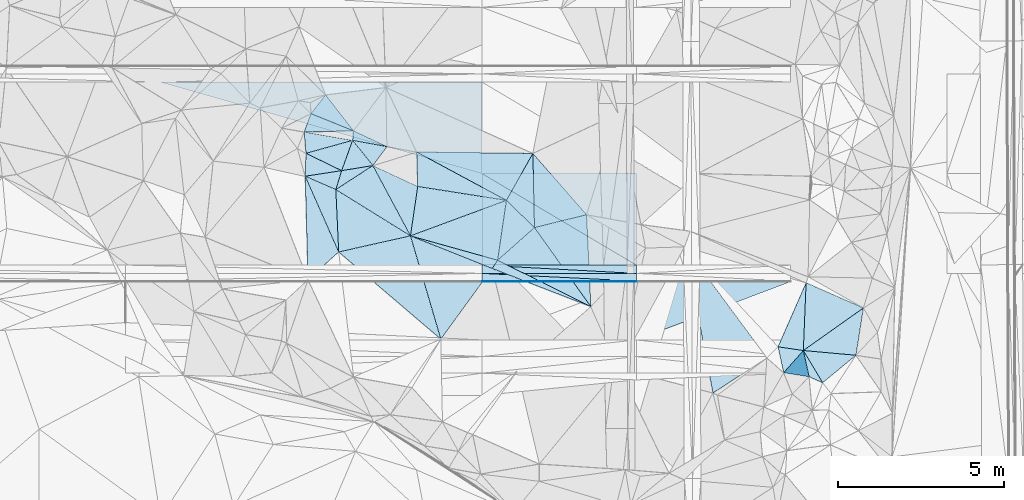
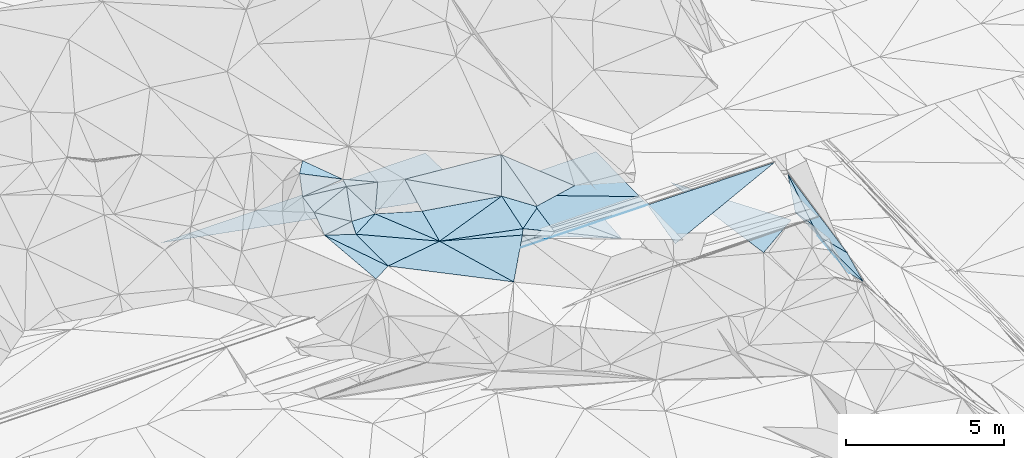
# One storey, part 60 of 275: 46 plates.
"""IFC2X3 building model written with IfcOpenShell, lengths in millimetres."""

import ifcopenshell
import ifcopenshell.guid

model = None  # the IFC model being written
_history = None  # IfcOwnerHistory: only IFC2X3 demands one
_inside = {}  # id of a spatial element -> (the spatial element, [elements in it])
_under = {}  # id of a project, library or spatial element -> (it, [spatial elements below it])
_declared = {}  # id of a project -> (the project, [libraries it declares])
_typed = {}  # id of a type object -> (the type object, [elements of that type])
_made_of = {}  # id of a material, layer set ... -> (it, [elements and type objects made of it])


def new_model(schema):
    """Start an empty IFC model of exactly this schema.

    Asked for "IFC4X3", IfcOpenShell would pick the latest addendum, in which some entities
    have other attributes; the version numbers below select the first issue.
    IFC2X3 requires an IfcOwnerHistory on every rooted entity: one is made here for all.
    """
    global model, _history
    if schema == "IFC4X3":
        model = ifcopenshell.file(schema_version=(4, 3, 0, 0))
    else:
        model = ifcopenshell.file(schema=schema)
    _inside.clear()
    _under.clear()
    _declared.clear()
    _typed.clear()
    _made_of.clear()
    _history = None
    if model.schema == "IFC2X3":
        org = make("IfcOrganization", Name="unknown")
        user = make(
            "IfcPersonAndOrganization",
            ThePerson=make("IfcPerson", FamilyName="unknown"),
            TheOrganization=org,
        )
        app = make(
            "IfcApplication",
            ApplicationDeveloper=org,
            Version="unknown",
            ApplicationFullName="unknown",
            ApplicationIdentifier="unknown",
        )
        _history = make(
            "IfcOwnerHistory",
            OwningUser=user,
            OwningApplication=app,
            ChangeAction="ADDED",
            CreationDate=0,
        )
    return model


def make(cls, **values):
    """One entity of the class cls with the attributes given. An attribute that is None is left unset."""
    return model.create_entity(
        cls, **{name: value for name, value in values.items() if value is not None}
    )


def rooted(cls, **values):
    """An entity with a GlobalId (a new one), such as an element, a storey or a relation."""
    return make(cls, GlobalId=ifcopenshell.guid.new(), OwnerHistory=_history, **values)


def si_unit(unit_type, name, prefix=None):
    """IfcSIUnit, for example si_unit("LENGTHUNIT", "METRE", prefix="MILLI")."""
    return make("IfcSIUnit", UnitType=unit_type, Prefix=prefix, Name=name)


def assignment(units):
    """IfcUnitAssignment: the units of a project."""
    return None if units is None else make("IfcUnitAssignment", Units=units)


def point(xyz):
    """IfcCartesianPoint."""
    return None if xyz is None else make("IfcCartesianPoint", Coordinates=xyz)


def direction(xyz):
    """IfcDirection."""
    return None if xyz is None else make("IfcDirection", DirectionRatios=xyz)


def frame(location, z_axis=None, x_axis=None):
    """IfcAxis2Placement3D, a coordinate frame: its origin and axes. An axis left out is left unset."""
    return make(
        "IfcAxis2Placement3D",
        Location=point(location),
        Axis=direction(z_axis),
        RefDirection=direction(x_axis),
    )


def origin_with_axes():
    """The frame at (0, 0, 0) with the z axis (0, 0, 1) and the x axis (1, 0, 0) written out."""
    return frame((0.0, 0.0, 0.0), z_axis=(0.0, 0.0, 1.0), x_axis=(1.0, 0.0, 0.0))


def place(relative_to, where):
    """IfcLocalPlacement: puts the frame where relative to a parent placement (None: the world)."""
    return make(
        "IfcLocalPlacement", PlacementRelTo=relative_to, RelativePlacement=where
    )


def context(
    kind, dimensions, precision=None, world=None, true_north=None, identifier=None
):
    """IfcGeometricRepresentationContext, for example the 3D "Model" context."""
    return make(
        "IfcGeometricRepresentationContext",
        ContextIdentifier=identifier,
        ContextType=kind,
        CoordinateSpaceDimension=dimensions,
        Precision=precision,
        WorldCoordinateSystem=world,
        TrueNorth=true_north,
    )


def subcontext(parent, identifier, kind, view, scale=None):
    """IfcGeometricRepresentationSubContext, for example "Body" below "Model"."""
    return make(
        "IfcGeometricRepresentationSubContext",
        ContextIdentifier=identifier,
        ContextType=kind,
        ParentContext=parent,
        TargetScale=scale,
        TargetView=view,
    )


def project(units=None, contexts=None):
    """IfcProject with its units and contexts."""
    return rooted(
        "IfcProject",
        Name="project",
        RepresentationContexts=contexts,
        UnitsInContext=assignment(units),
    )


def spatial(cls, under=None, at=None, **own):
    """A site, building, storey or space (cls), placed at a placement, below another one or the project."""
    s = rooted(cls, ObjectPlacement=at, **own)
    if under is not None:
        _under.setdefault(under.id(), (under, []))[1].append(s)
    return s


def polyline(points):
    """IfcPolyline through the points."""
    return make("IfcPolyline", Points=[point(p) for p in points])


def outline(outer, holes=None, kind="AREA"):
    """IfcArbitraryClosedProfileDef: a profile drawn as a closed curve; with holes, ...WithVoids."""
    if holes is None:
        return make("IfcArbitraryClosedProfileDef", ProfileType=kind, OuterCurve=outer)
    return make(
        "IfcArbitraryProfileDefWithVoids",
        ProfileType=kind,
        OuterCurve=outer,
        InnerCurves=holes,
    )


def extrude(swept, where, along, depth):
    """IfcExtrudedAreaSolid: the profile swept, set in the frame where, extruded along a direction by depth."""
    return make(
        "IfcExtrudedAreaSolid",
        SweptArea=swept,
        Position=where,
        ExtrudedDirection=direction(along),
        Depth=depth,
    )


def shape(context_of_items, identifier, shape_type, items):
    """IfcShapeRepresentation: the items that make up one representation, for example the "Body"."""
    return make(
        "IfcShapeRepresentation",
        ContextOfItems=context_of_items,
        RepresentationIdentifier=identifier,
        RepresentationType=shape_type,
        Items=items,
    )


def material(Name=None, Category=None):
    """IfcMaterial."""
    return make("IfcMaterial", Name=Name, Category=Category)


def made_of(thing, what):
    """Note that an element or type object is made of a material, layer set ...; save() writes the relation."""
    if what is not None:
        _made_of.setdefault(what.id(), (what, []))[1].append(thing)
    return thing


def type_object(cls, material=None, **own):
    """A type object (cls), such as IfcWallType, which elements share."""
    return made_of(rooted(cls, **own), material)


def element(
    cls,
    number,
    at=None,
    inside=None,
    cuts=None,
    type_object=None,
    material=None,
    context=None,
    identifier="Body",
    shape_type=None,
    held_by="IfcProductDefinitionShape",
    body=None,
    shapes=None,
    **own,
):
    """One element of the class cls, such as IfcWall. Its Tag is "e" and its number.

    at: its placement. inside: the storey or other place that contains it. cuts: it is an
    opening in that element (IfcRelVoidsElement). A single representation is given by context,
    identifier, shape_type and body (its items); several are given by shapes. held_by: the class
    of the entity that holds the representations. save() writes the other relations.
    """
    e = rooted(cls, Tag="e%d" % number, ObjectPlacement=at, **own)
    if body is not None:
        shapes = [shape(context, identifier, shape_type, body)]
    if shapes is not None:
        e.Representation = make(held_by, Representations=shapes)
    if inside is not None:
        _inside.setdefault(inside.id(), (inside, []))[1].append(e)
    if cuts is not None:
        rooted(
            "IfcRelVoidsElement", RelatingBuildingElement=cuts, RelatedOpeningElement=e
        )
    if type_object is not None:
        _typed.setdefault(type_object.id(), (type_object, []))[1].append(e)
    return made_of(e, material)


def aggregate(whole, parts):
    """IfcRelAggregates: a whole, such as a stair, and the parts it consists of."""
    return rooted("IfcRelAggregates", RelatingObject=whole, RelatedObjects=parts)


def save(model, path):
    """Write the relations noted so far, then the file.

    IfcRelAggregates (storeys below a building ...), IfcRelContainedInSpatialStructure (elements
    in a storey), IfcRelDefinesByType, IfcRelAssociatesMaterial and IfcRelDeclares: one each for
    every whole, place, type object, material and project.
    """
    for whole, parts in _under.values():
        aggregate(whole, parts)
    for where, things in _inside.values():
        rooted(
            "IfcRelContainedInSpatialStructure",
            RelatedElements=things,
            RelatingStructure=where,
        )
    for kind, things in _typed.values():
        rooted("IfcRelDefinesByType", RelatedObjects=things, RelatingType=kind)
    for what, things in _made_of.values():
        rooted("IfcRelAssociatesMaterial", RelatedObjects=things, RelatingMaterial=what)
    for by, libraries in _declared.values():
        rooted("IfcRelDeclares", RelatingContext=by, RelatedDefinitions=libraries)
    model.write(path)


model = new_model("IFC2X3")

# Units and contexts
model_context = context("Model", 3, precision=1e-05, world=origin_with_axes())
body_context = subcontext(model_context, "Body", "Model", "MODEL_VIEW")
ifc_project = project(units=[si_unit("LENGTHUNIT", "METRE", prefix="MILLI"), si_unit("AREAUNIT", "SQUARE_METRE"), si_unit("VOLUMEUNIT", "CUBIC_METRE"), si_unit("MASSUNIT", "GRAM", prefix="KILO"), si_unit("TIMEUNIT", "SECOND"), si_unit("PLANEANGLEUNIT", "RADIAN"), si_unit("SOLIDANGLEUNIT", "STERADIAN"), si_unit("THERMODYNAMICTEMPERATUREUNIT", "DEGREE_CELSIUS"), si_unit("LUMINOUSINTENSITYUNIT", "LUMEN")], contexts=[model_context])

# Site, building, storey
site_placement = place(None, origin_with_axes())
site = spatial("IfcSite", under=ifc_project, at=site_placement, CompositionType="ELEMENT")
building_placement = place(site_placement, origin_with_axes())
building = spatial("IfcBuilding", under=site, at=building_placement, Name="Undefined", CompositionType="ELEMENT")
storey_placement = place(building_placement, origin_with_axes())
storey = spatial("IfcBuildingStorey", under=building, at=storey_placement, Name="Undefined", CompositionType="ELEMENT", Elevation=0.0)

# Plates
ifc_material = material()
plate_type_1 = type_object("IfcPlateType", PredefinedType="NOTDEFINED")
for number, where, z_axis, x_axis, name in (
    (1, (-105469.357591883, 60542.9469194419, 49093.5671622672), (0.0070360534464846, 0.0249911698384873, -0.999662910876462), (-0.999975239635043, 5.72709690146696e-05, -0.00703682008264182), "00_PR"),
    (2, (-110107.970218176, 63293.2126112897, 49129.6741619064), (0.0070360534464846, 0.0249911698384873, -0.999662910876462), (0.99997523963564, -5.72709999785377e-05, 0.00703681999743575), "00_PR"),
):
    element("IfcPlate", number, at=place(storey_placement, frame(where, z_axis=z_axis, x_axis=x_axis)), inside=storey, type_object=plate_type_1, material=ifc_material, Name=name, context=body_context, shape_type="SweptSolid", body=[
        extrude(outline(polyline([(0.0, 0.0), (4638.88525390625, 2.71393219009042e-09), (4638.4013671875, 2750.85913085938), (0.0, 0.0)])), frame((-8.85201319254618e-08, 2.18876761149539e-07, -0.5000001331573), z_axis=(0.0, 0.0, 1.0), x_axis=(1.0, 0.0, 0.0)), (0.0, 0.0, 1.0), 1.0),
    ])
plate_1_placement = place(storey_placement, frame((-119776.166734468, 66043.7427297711, 48980.4271662069), z_axis=(0.00832149793297365, -0.0249918019511436, -0.9996530210565), x_axis=(0.999965340787191, -5.73519775278889e-05, 0.0083254990906575)))
element("IfcPlate", 3, at=plate_1_placement, inside=storey, type_object=plate_type_1, material=ifc_material, Name="00_PR", context=body_context, shape_type="SweptSolid", body=[
    extrude(outline(polyline([(0.0, 0.0), (9668.689453125, -4.80504240840673e-08), (9669.2626953125, 2750.85913085938), (0.0, 0.0)])), frame((-8.85201319254618e-08, 2.18876761149539e-07, -0.5000001331573), z_axis=(0.0, 0.0, 1.0), x_axis=(1.0, 0.0, 0.0)), (0.0, 0.0, 1.0), 1.0),
])
plate_type_2 = type_object("IfcPlateType", PredefinedType="NOTDEFINED")
plate_2_placement = place(storey_placement, frame((-105469.371915904, 60292.9469172956, 49087.3171623926), z_axis=(0.0070360534464846, 0.0249911698384873, -0.999662910876462), x_axis=(-0.998531697023623, 0.0538718169725224, -0.00568131808672126)))
element("IfcPlate", 4, at=plate_2_placement, inside=storey, type_object=plate_type_2, material=ifc_material, Name="00_PR", context=body_context, shape_type="SweptSolid", body=[
    extrude(outline(polyline([(0.0, 0.0), (4645.5771484375, 2.16532498598099e-08), (13.4181432723999, 249.717880249023), (0.0, 0.0)])), frame((-8.85201319254618e-08, 2.18876761149539e-07, -0.5000001331573), z_axis=(0.0, 0.0, 1.0), x_axis=(1.0, 0.0, 0.0)), (0.0, 0.0, 1.0), 1.0),
])
plate_3_placement = place(storey_placement, frame((-105469.371915904, 60292.9469172956, 49087.3171623926), z_axis=(0.0070360534464846, 0.0249911698384873, -0.999662910876462), x_axis=(-0.999975239635043, 5.72709690146696e-05, -0.00703682008264182)))
element("IfcPlate", 5, at=plate_3_placement, inside=storey, type_object=plate_type_2, material=ifc_material, Name="00_PR", context=body_context, shape_type="SweptSolid", body=[
    extrude(outline(polyline([(0.0, 0.0), (4638.88525390625, 2.71393219009042e-09), (4638.8408203125, 250.078109741211), (0.0, 0.0)])), frame((-8.85201319254618e-08, 2.18876761149539e-07, -0.5000001331573), z_axis=(0.0, 0.0, 1.0), x_axis=(1.0, 0.0, 0.0)), (0.0, 0.0, 1.0), 1.0),
])
plate_type_3 = type_object("IfcPlateType", PredefinedType="NOTDEFINED")
plate_4_placement = place(storey_placement, frame((-114002.048668987, 64294.633869478, 50199.6265021992), z_axis=(-0.206176618696552, 0.632090820507885, -0.74696211184539), x_axis=(0.480916574477052, -0.599349489283121, -0.639921431184579)))
element("IfcPlate", 6, at=plate_4_placement, inside=storey, type_object=plate_type_3, material=ifc_material, Name="00", context=body_context, shape_type="SweptSolid", body=[
    extrude(outline(polyline([(0.0, 0.0), (1265.78039550781, -6.86122803017497e-09), (822.654541015625, 851.198852539063), (0.0, 0.0)])), frame((-8.85201319254618e-08, 2.18876761149539e-07, -0.5000001331573), z_axis=(0.0, 0.0, 1.0), x_axis=(1.0, 0.0, 0.0)), (0.0, 0.0, 1.0), 1.0),
])
plate_type_4 = type_object("IfcPlateType", PredefinedType="NOTDEFINED")
plate_5_placement = place(storey_placement, frame((-110108.156426157, 60043.2250561732, 49042.1746302213), z_axis=(0.00703090098467657, 0.0499351917126977, -0.998727712171821), x_axis=(5.44309859502141e-05, 0.9987523778888, 0.0499368070538782)))
element("IfcPlate", 7, at=plate_5_placement, inside=storey, type_object=plate_type_4, material=ifc_material, Name="00_PR", context=body_context, shape_type="SweptSolid", body=[
    extrude(outline(polyline([(0.0, 0.0), (20.0253086090088, -9.45874489843845e-11), (21.6424503326416, 4638.884765625), (0.0, 0.0)])), frame((-8.85201319254618e-08, 2.18876761149539e-07, -0.5000001331573), z_axis=(0.0, 0.0, 1.0), x_axis=(1.0, 0.0, 0.0)), (0.0, 0.0, 1.0), 1.0),
])
plate_6_placement = place(storey_placement, frame((-110108.156426157, 60043.2250561732, 49042.1746302213), z_axis=(0.00703090098467657, 0.0499351917126977, -0.998727712171821), x_axis=(0.999964652538682, 0.00425413401797967, 0.00725231114546895)))
element("IfcPlate", 8, at=plate_6_placement, inside=storey, type_object=plate_type_4, material=ifc_material, Name="00_PR", context=body_context, shape_type="SweptSolid", body=[
    extrude(outline(polyline([(0.0, 0.0), (4638.93505859375, -2.84198904410005e-08), (4638.841796875, 20.0250911712646), (0.0, 0.0)])), frame((-8.85201319254618e-08, 2.18876761149539e-07, -0.5000001331573), z_axis=(0.0, 0.0, 1.0), x_axis=(1.0, 0.0, 0.0)), (0.0, 0.0, 1.0), 1.0),
])
plate_type_5 = type_object("IfcPlateType", PredefinedType="NOTDEFINED")
plate_7_placement = place(storey_placement, frame((-112075.479837508, 63943.5436245506, 50019.5718020555), z_axis=(0.0483725159620613, 0.514104819242687, -0.85636226827841), x_axis=(0.857073951160774, -0.461637543885496, -0.228724769793361)))
element("IfcPlate", 9, at=plate_7_placement, inside=storey, type_object=plate_type_5, material=ifc_material, Name="00", context=body_context, shape_type="SweptSolid", body=[
    extrude(outline(polyline([(0.0, 0.0), (3147.88818359375, 5.07861841470003e-09), (646.909912109375, 1019.61151123047), (0.0, 0.0)])), frame((-8.85201319254618e-08, 2.18876761149539e-07, -0.5000001331573), z_axis=(0.0, 0.0, 1.0), x_axis=(1.0, 0.0, 0.0)), (0.0, 0.0, 1.0), 1.0),
])
plate_type_6 = type_object("IfcPlateType", PredefinedType="NOTDEFINED")
plate_8_placement = place(storey_placement, frame((-100449.703694748, 57974.7372312111, 47389.7454523631), z_axis=(-0.802912705869566, 0.310105280486058, -0.509083393726289), x_axis=(0.0358324467769765, 0.877592420314981, 0.478066501193787)))
element("IfcPlate", 10, at=plate_8_placement, inside=storey, type_object=plate_type_6, material=ifc_material, Name="00", context=body_context, shape_type="SweptSolid", body=[
    extrude(outline(polyline([(0.0, 0.0), (2321.85278320313, -7.37782102078199e-09), (198.332992553711, 3024.57666015625), (0.0, 0.0)])), frame((-8.85201319254618e-08, 2.18876761149539e-07, -0.5000001331573), z_axis=(0.0, 0.0, 1.0), x_axis=(1.0, 0.0, 0.0)), (0.0, 0.0, 1.0), 1.0),
])
plate_type_7 = type_object("IfcPlateType", PredefinedType="NOTDEFINED")
for number, where, z_axis, x_axis, name in (
    (11, (-105469.385157224, 60062.959709921, 49075.8176310477), (0.00703090098467657, 0.0499351917126977, -0.998727712171821), (-0.999975239635043, 5.72709690146696e-05, -0.00703682008264182), "00_PR"),
    (12, (-110108.142106687, 60293.2250577911, 49054.6746302254), (0.00703090098467657, 0.0499351917126977, -0.998727712171821), (0.99997523963564, -5.72709999785377e-05, 0.00703681999743575), "00_PR"),
):
    element("IfcPlate", number, at=place(storey_placement, frame(where, z_axis=z_axis, x_axis=x_axis)), inside=storey, type_object=plate_type_7, material=ifc_material, Name=name, context=body_context, shape_type="SweptSolid", body=[
        extrude(outline(polyline([(0.0, 0.0), (4638.88525390625, 2.71393219009042e-09), (4638.80419921875, 230.286987304688), (0.0, 0.0)])), frame((-8.85201319254618e-08, 2.18876761149539e-07, -0.5000001331573), z_axis=(0.0, 0.0, 1.0), x_axis=(1.0, 0.0, 0.0)), (0.0, 0.0, 1.0), 1.0),
    ])
plate_type_8 = type_object("IfcPlateType", PredefinedType="NOTDEFINED")
plate_9_placement = place(storey_placement, frame((-114331.680726985, 63383.2573209995, 49519.5057325526), z_axis=(0.0222713017527005, 0.149446459105017, -0.988518965412001), x_axis=(-0.290150923722949, -0.945240675904919, -0.149440643994637)))
element("IfcPlate", 13, at=plate_9_placement, inside=storey, type_object=plate_type_8, material=ifc_material, Name="00", context=body_context, shape_type="SweptSolid", body=[
    extrude(outline(polyline([(0.0, 0.0), (602.245788574219, 0.0), (483.689544677734, 998.771423339844), (0.0, 0.0)])), frame((-8.85201319254618e-08, 2.18876761149539e-07, -0.5000001331573), z_axis=(0.0, 0.0, 1.0), x_axis=(1.0, 0.0, 0.0)), (0.0, 0.0, 1.0), 1.0),
])
plate_type_9 = type_object("IfcPlateType", PredefinedType="NOTDEFINED")
plate_10_placement = place(storey_placement, frame((-115458.430576505, 64547.1305341542, 50159.5345688278), z_axis=(0.0871246949560636, 0.354924955467615, -0.930826279987369), x_axis=(0.984928129317309, -0.170836034889792, 0.0270486462256255)))
element("IfcPlate", 14, at=plate_10_placement, inside=storey, type_object=plate_type_9, material=ifc_material, Name="00", context=body_context, shape_type="SweptSolid", body=[
    extrude(outline(polyline([(0.0, 0.0), (1478.81713867188, 5.23868948221207e-09), (157.085006713867, 670.167358398438), (0.0, 0.0)])), frame((-8.85201319254618e-08, 2.18876761149539e-07, -0.5000001331573), z_axis=(0.0, 0.0, 1.0), x_axis=(1.0, 0.0, 0.0)), (0.0, 0.0, 1.0), 1.0),
])
plate_type_10 = type_object("IfcPlateType", PredefinedType="NOTDEFINED")
plate_11_placement = place(storey_placement, frame((-105469.487855444, 58293.0556696204, 48637.3319281114), z_axis=(0.00434030611226815, 0.242533626751396, -0.970133290655293), x_axis=(5.55829351537207e-05, 0.970142499049491, 0.242535623050607)))
element("IfcPlate", 15, at=plate_11_placement, inside=storey, type_object=plate_type_10, material=ifc_material, Name="00_PR", context=body_context, shape_type="SweptSolid", body=[
    extrude(outline(polyline([(0.0, 0.0), (1803.85876464844, 6.72298483550549e-09), (1808.8759765625, 4638.8125), (0.0, 0.0)])), frame((-8.85201319254618e-08, 2.18876761149539e-07, -0.5000001331573), z_axis=(0.0, 0.0, 1.0), x_axis=(1.0, 0.0, 0.0)), (0.0, 0.0, 1.0), 1.0),
])
plate_type_11 = type_object("IfcPlateType", PredefinedType="NOTDEFINED")
plate_12_placement = place(storey_placement, frame((-100449.742102399, 57974.6028025237, 47389.7631445813), z_axis=(-0.879720303766565, 0.0412433834713075, -0.473699451615369), x_axis=(0.193307956188442, -0.879166568690718, -0.43554354382867)))
element("IfcPlate", 16, at=plate_12_placement, inside=storey, type_object=plate_type_11, material=ifc_material, Name="00", context=body_context, shape_type="SweptSolid", body=[
    extrude(outline(polyline([(0.0, 0.0), (895.432861328125, -1.34605215862393e-09), (18.2034873962402, 1369.03930664063), (0.0, 0.0)])), frame((-8.85201319254618e-08, 2.18876761149539e-07, -0.5000001331573), z_axis=(0.0, 0.0, 1.0), x_axis=(1.0, 0.0, 0.0)), (0.0, 0.0, 1.0), 1.0),
])
plate_type_12 = type_object("IfcPlateType", PredefinedType="NOTDEFINED")
plate_13_placement = place(storey_placement, frame((-115427.603941093, 63216.0448812287, 49469.5822782821), z_axis=(-0.0455535299613272, 0.547709977917874, -0.83542722962402), x_axis=(0.0287929817530451, 0.836667818432838, 0.546953312267696)))
element("IfcPlate", 17, at=plate_13_placement, inside=storey, type_object=plate_type_12, material=ifc_material, Name="00", context=body_context, shape_type="SweptSolid", body=[
    extrude(outline(polyline([(0.0, 0.0), (822.739318847656, 3.23052518069744e-09), (198.969467163086, 1091.74682617188), (0.0, 0.0)])), frame((-8.85201319254618e-08, 2.18876761149539e-07, -0.5000001331573), z_axis=(0.0, 0.0, 1.0), x_axis=(1.0, 0.0, 0.0)), (0.0, 0.0, 1.0), 1.0),
])
plate_type_13 = type_object("IfcPlateType", PredefinedType="NOTDEFINED")
plate_14_placement = place(storey_placement, frame((-115427.725097584, 63215.7409683787, 49469.5221013217), z_axis=(-0.28786785864985, -0.060115259935178, -0.955781487307259), x_axis=(0.403511411319082, -0.912724796164009, -0.0641247799423198)))
element("IfcPlate", 18, at=plate_14_placement, inside=storey, type_object=plate_type_13, material=ifc_material, Name="00", context=body_context, shape_type="SweptSolid", body=[
    extrude(outline(polyline([(0.0, 0.0), (2495.13525390625, -6.30097929388285e-09), (2863.17138671875, 1232.05090332031), (0.0, 0.0)])), frame((-8.85201319254618e-08, 2.18876761149539e-07, -0.5000001331573), z_axis=(0.0, 0.0, 1.0), x_axis=(1.0, 0.0, 0.0)), (0.0, 0.0, 1.0), 1.0),
])
plate_type_14 = type_object("IfcPlateType", PredefinedType="NOTDEFINED")
plate_15_placement = place(storey_placement, frame((-114814.684574136, 65662.6499893864, 50649.5165121762), z_axis=(-0.201505438951403, 0.156275692855278, -0.966940259734594), x_axis=(0.593640454844651, -0.765735069482858, -0.247468813663297)))
element("IfcPlate", 19, at=plate_15_placement, inside=storey, type_object=plate_type_14, material=ifc_material, Name="00", context=body_context, shape_type="SweptSolid", body=[
    extrude(outline(polyline([(0.0, 0.0), (1414.31958007813, 4.05270839110017e-09), (172.73323059082, 694.739685058594), (0.0, 0.0)])), frame((-8.85201319254618e-08, 2.18876761149539e-07, -0.5000001331573), z_axis=(0.0, 0.0, 1.0), x_axis=(1.0, 0.0, 0.0)), (0.0, 0.0, 1.0), 1.0),
])
plate_type_15 = type_object("IfcPlateType", PredefinedType="NOTDEFINED")
plate_16_placement = place(storey_placement, frame((-115427.589059837, 63215.8025887112, 49469.5010516445), z_axis=(-0.0157932753391051, 0.0631253900808877, -0.997880632932216), x_axis=(0.915850512367754, -0.399544973921007, -0.0397699988707988)))
element("IfcPlate", 20, at=plate_16_placement, inside=storey, type_object=plate_type_15, material=ifc_material, Name="00", context=body_context, shape_type="SweptSolid", body=[
    extrude(outline(polyline([(0.0, 0.0), (1005.78326416016, -6.50288711767644e-09), (1838.3681640625, 1687.03955078125), (0.0, 0.0)])), frame((-8.85201319254618e-08, 2.18876761149539e-07, -0.5000001331573), z_axis=(0.0, 0.0, 1.0), x_axis=(1.0, 0.0, 0.0)), (0.0, 0.0, 1.0), 1.0),
])
plate_type_16 = type_object("IfcPlateType", PredefinedType="NOTDEFINED")
plate_17_placement = place(storey_placement, frame((-112262.179835873, 61422.6101959409, 49219.5048544125), z_axis=(0.0409771977769723, 0.132940613743267, -0.990276558583465), x_axis=(0.963005616311493, -0.269456257889118, 0.00367532813701468)))
element("IfcPlate", 21, at=plate_17_placement, inside=storey, type_object=plate_type_16, material=ifc_material, Name="00", context=body_context, shape_type="SweptSolid", body=[
    extrude(outline(polyline([(0.0, 0.0), (2720.84545898438, 1.52213033288717e-08), (2629.47680664063, 285.222320556641), (0.0, 0.0)])), frame((-8.85201319254618e-08, 2.18876761149539e-07, -0.5000001331573), z_axis=(0.0, 0.0, 1.0), x_axis=(1.0, 0.0, 0.0)), (0.0, 0.0, 1.0), 1.0),
])
plate_type_17 = type_object("IfcPlateType", PredefinedType="NOTDEFINED")
plate_18_placement = place(storey_placement, frame((-114331.695413921, 63383.4824771339, 49519.5999046945), z_axis=(-0.0071116838571498, 0.599748360325922, -0.800157064731096), x_axis=(-0.852726859842235, 0.414312842744918, 0.318122257693842)))
element("IfcPlate", 22, at=plate_18_placement, inside=storey, type_object=plate_type_17, material=ifc_material, Name="00", context=body_context, shape_type="SweptSolid", body=[
    extrude(outline(polyline([(0.0, 0.0), (1257.37817382813, 3.40151018463075e-09), (312.634643554688, 1141.7353515625), (0.0, 0.0)])), frame((-8.85201319254618e-08, 2.18876761149539e-07, -0.5000001331573), z_axis=(0.0, 0.0, 1.0), x_axis=(1.0, 0.0, 0.0)), (0.0, 0.0, 1.0), 1.0),
])
plate_type_18 = type_object("IfcPlateType", PredefinedType="NOTDEFINED")
plate_19_placement = place(storey_placement, frame((-100449.723178664, 57974.621852287, 47389.7330895001), z_axis=(-0.841874199148825, 0.0793435965632446, -0.533809354069347), x_axis=(0.375163311381166, -0.624993750173844, -0.684569428208091)))
element("IfcPlate", 23, at=plate_19_placement, inside=storey, type_object=plate_type_18, material=ifc_material, Name="00", context=body_context, shape_type="SweptSolid", body=[
    extrude(outline(polyline([(0.0, 0.0), (1548.41857910156, 4.32555680163205e-09), (823.937438964844, 350.609619140625), (0.0, 0.0)])), frame((-8.85201319254618e-08, 2.18876761149539e-07, -0.5000001331573), z_axis=(0.0, 0.0, 1.0), x_axis=(1.0, 0.0, 0.0)), (0.0, 0.0, 1.0), 1.0),
])
plate_type_19 = type_object("IfcPlateType", PredefinedType="NOTDEFINED")
plate_20_placement = place(storey_placement, frame((-108534.346531801, 61671.2385944513, 49089.5223250345), z_axis=(0.0457212690600067, 0.292019857613634, -0.955318778374452), x_axis=(-0.706124938301726, 0.685899094044843, 0.175869281845486)))
element("IfcPlate", 24, at=plate_20_placement, inside=storey, type_object=plate_type_19, material=ifc_material, Name="00", context=body_context, shape_type="SweptSolid", body=[
    extrude(outline(polyline([(0.0, 0.0), (1194.06872558594, 2.69938027486205e-09), (1683.15283203125, 1616.35290527344), (0.0, 0.0)])), frame((-8.85201319254618e-08, 2.18876761149539e-07, -0.5000001331573), z_axis=(0.0, 0.0, 1.0), x_axis=(1.0, 0.0, 0.0)), (0.0, 0.0, 1.0), 1.0),
])
plate_type_20 = type_object("IfcPlateType", PredefinedType="NOTDEFINED")
plate_21_placement = place(storey_placement, frame((-114506.517402095, 62814.0172290634, 49429.5176174947), z_axis=(-0.166735035347733, 0.203702874702573, -0.964730307819495), x_axis=(0.290150923757659, 0.945240675901422, 0.149440643949362)))
element("IfcPlate", 25, at=plate_21_placement, inside=storey, type_object=plate_type_20, material=ifc_material, Name="00", context=body_context, shape_type="SweptSolid", body=[
    extrude(outline(polyline([(0.0, 0.0), (602.245788574219, 0.0), (999.259765625, 873.658935546875), (0.0, 0.0)])), frame((-8.85201319254618e-08, 2.18876761149539e-07, -0.5000001331573), z_axis=(0.0, 0.0, 1.0), x_axis=(1.0, 0.0, 0.0)), (0.0, 0.0, 1.0), 1.0),
])
plate_type_21 = type_object("IfcPlateType", PredefinedType="NOTDEFINED")
plate_22_placement = place(storey_placement, frame((-108580.786508316, 63903.0922214755, 49769.5320828388), z_axis=(-0.0629386924872601, 0.34681345097606, -0.935820042107493), x_axis=(-0.471820408719494, -0.83661559394782, -0.278316097053522)))
element("IfcPlate", 26, at=plate_22_placement, inside=storey, type_object=plate_type_21, material=ifc_material, Name="00", context=body_context, shape_type="SweptSolid", body=[
    extrude(outline(polyline([(0.0, 0.0), (1688.72729492188, -9.63336788117886e-09), (1545.54260253906, 3144.63012695313), (0.0, 0.0)])), frame((-8.85201319254618e-08, 2.18876761149539e-07, -0.5000001331573), z_axis=(0.0, 0.0, 1.0), x_axis=(1.0, 0.0, 0.0)), (0.0, 0.0, 1.0), 1.0),
])
plate_type_22 = type_object("IfcPlateType", PredefinedType="NOTDEFINED")
plate_23_placement = place(storey_placement, frame((-108580.781680813, 63903.0638283342, 49769.5222261438), z_axis=(-0.0532851773060477, 0.2900276212187, -0.955533708881945), x_axis=(0.636381853387958, -0.727544317106336, -0.256315047012038)))
element("IfcPlate", 27, at=plate_23_placement, inside=storey, type_object=plate_type_22, material=ifc_material, Name="00", context=body_context, shape_type="SweptSolid", body=[
    extrude(outline(polyline([(0.0, 0.0), (2535.94165039063, 8.36735125631094e-09), (1827.56567382813, 1451.06982421875), (0.0, 0.0)])), frame((-8.85201319254618e-08, 2.18876761149539e-07, -0.5000001331573), z_axis=(0.0, 0.0, 1.0), x_axis=(1.0, 0.0, 0.0)), (0.0, 0.0, 1.0), 1.0),
])
plate_type_23 = type_object("IfcPlateType", PredefinedType="NOTDEFINED")
plate_24_placement = place(storey_placement, frame((-100366.483916108, 60012.3901407131, 48499.7207128603), z_axis=(-0.758691778046555, 0.335253320659996, -0.558562437790981), x_axis=(-0.0358324467754349, -0.87759242030928, -0.478066501204367)))
element("IfcPlate", 28, at=plate_24_placement, inside=storey, type_object=plate_type_23, material=ifc_material, Name="00", context=body_context, shape_type="SweptSolid", body=[
    extrude(outline(polyline([(0.0, 0.0), (2321.85278320313, -7.37782102078199e-09), (1724.78637695313, 1201.71203613281), (0.0, 0.0)])), frame((-8.85201319254618e-08, 2.18876761149539e-07, -0.5000001331573), z_axis=(0.0, 0.0, 1.0), x_axis=(1.0, 0.0, 0.0)), (0.0, 0.0, 1.0), 1.0),
])
plate_type_24 = type_object("IfcPlateType", PredefinedType="NOTDEFINED")
plate_25_placement = place(storey_placement, frame((-98642.9137952217, 59254.5338675674, 45319.7138504113), z_axis=(-0.795822732695787, 0.197871547456743, -0.572287540342863), x_axis=(-0.15448966675282, -0.980173600765406, -0.124067140005651)))
element("IfcPlate", 29, at=plate_25_placement, inside=storey, type_object=plate_type_24, material=ifc_material, Name="00", context=body_context, shape_type="SweptSolid", body=[
    extrude(outline(polyline([(0.0, 0.0), (1450.82739257813, -2.2409949451685e-09), (1276.78869628906, 2749.0380859375), (0.0, 0.0)])), frame((-8.85201319254618e-08, 2.18876761149539e-07, -0.5000001331573), z_axis=(0.0, 0.0, 1.0), x_axis=(1.0, 0.0, 0.0)), (0.0, 0.0, 1.0), 1.0),
])
plate_type_25 = type_object("IfcPlateType", PredefinedType="NOTDEFINED")
plate_26_placement = place(storey_placement, frame((-113974.957980391, 64579.9038317415, 50299.6220610669), z_axis=(0.0569882705246253, 0.652246011102015, -0.755862076058935), x_axis=(-0.995337928919566, -0.0218893271885485, -0.0939322341336652)))
element("IfcPlate", 30, at=plate_26_placement, inside=storey, type_object=plate_type_25, material=ifc_material, Name="00", context=body_context, shape_type="SweptSolid", body=[
    extrude(outline(polyline([(0.0, 0.0), (1490.43615722656, 9.12405084818602e-09), (1228.16394042969, 718.201416015625), (0.0, 0.0)])), frame((-8.85201319254618e-08, 2.18876761149539e-07, -0.5000001331573), z_axis=(0.0, 0.0, 1.0), x_axis=(1.0, 0.0, 0.0)), (0.0, 0.0, 1.0), 1.0),
])
plate_type_26 = type_object("IfcPlateType", PredefinedType="NOTDEFINED")
plate_27_placement = place(storey_placement, frame((-99868.7947203495, 57006.9038220644, 46329.7123588574), z_axis=(-0.804624309169291, 0.147116959270105, -0.57527065055412), x_axis=(-0.375163311365685, 0.624993750170777, 0.684569428219375)))
element("IfcPlate", 31, at=plate_27_placement, inside=storey, type_object=plate_type_26, material=ifc_material, Name="00", context=body_context, shape_type="SweptSolid", body=[
    extrude(outline(polyline([(0.0, 0.0), (1548.41857910156, 4.32555680163205e-09), (-674.49462890625, 1626.70129394531), (0.0, 0.0)])), frame((-8.85201319254618e-08, 2.18876761149539e-07, -0.5000001331573), z_axis=(0.0, 0.0, 1.0), x_axis=(1.0, 0.0, 0.0)), (0.0, 0.0, 1.0), 1.0),
])
plate_type_27 = type_object("IfcPlateType", PredefinedType="NOTDEFINED")
plate_28_placement = place(storey_placement, frame((-101040.93762793, 57308.591338979, 48429.7230425944), z_axis=(-0.821439042421512, -0.135756815457702, -0.553902506441714), x_axis=(-0.211710904231993, 0.974439490089014, 0.0751410219808955)))
element("IfcPlate", 32, at=plate_28_placement, inside=storey, type_object=plate_type_27, material=ifc_material, Name="00", context=body_context, shape_type="SweptSolid", body=[
    extrude(outline(polyline([(0.0, 0.0), (798.498596191406, 2.34285835176706e-09), (445.586273193359, 1294.62463378906), (0.0, 0.0)])), frame((-8.85201319254618e-08, 2.18876761149539e-07, -0.5000001331573), z_axis=(0.0, 0.0, 1.0), x_axis=(1.0, 0.0, 0.0)), (0.0, 0.0, 1.0), 1.0),
])
plate_type_28 = type_object("IfcPlateType", PredefinedType="NOTDEFINED")
plate_29_placement = place(storey_placement, frame((-112044.001328373, 62907.6254548559, 49399.5039965337), z_axis=(0.0592752052329127, 0.111531012191403, -0.991991574240506), x_axis=(-0.144318547803909, -0.982341380125705, -0.119069600035006)))
element("IfcPlate", 33, at=plate_29_placement, inside=storey, type_object=plate_type_28, material=ifc_material, Name="00", context=body_context, shape_type="SweptSolid", body=[
    extrude(outline(polyline([(0.0, 0.0), (1511.72082519531, -5.03496266901493e-09), (-421.109497070313, 1427.43359375), (0.0, 0.0)])), frame((-8.85201319254618e-08, 2.18876761149539e-07, -0.5000001331573), z_axis=(0.0, 0.0, 1.0), x_axis=(1.0, 0.0, 0.0)), (0.0, 0.0, 1.0), 1.0),
])
plate_type_29 = type_object("IfcPlateType", PredefinedType="NOTDEFINED")
plate_30_placement = place(storey_placement, frame((-109377.540048383, 62490.1646542138, 49299.5038652603), z_axis=(-0.0179689617760427, 0.122911100701603, -0.992254996327563), x_axis=(-0.937520264499313, -0.346957850025448, -0.0260000761317602)))
element("IfcPlate", 34, at=plate_30_placement, inside=storey, type_object=plate_type_29, material=ifc_material, Name="00", context=body_context, shape_type="SweptSolid", body=[
    extrude(outline(polyline([(0.0, 0.0), (3076.9140625, 1.22381607070565e-08), (2352.45434570313, 1326.82263183594), (0.0, 0.0)])), frame((-8.85201319254618e-08, 2.18876761149539e-07, -0.5000001331573), z_axis=(0.0, 0.0, 1.0), x_axis=(1.0, 0.0, 0.0)), (0.0, 0.0, 1.0), 1.0),
])
plate_type_30 = type_object("IfcPlateType", PredefinedType="NOTDEFINED")
plate_31_placement = place(storey_placement, frame((-114506.466630956, 62813.9380317641, 49429.501562042), z_axis=(-0.065190754891606, 0.0453034452233425, -0.996843901183911), x_axis=(0.83869480910385, 0.543767280266197, -0.0301357278684133)))
element("IfcPlate", 35, at=plate_31_placement, inside=storey, type_object=plate_type_30, material=ifc_material, Name="00", context=body_context, shape_type="SweptSolid", body=[
    extrude(outline(polyline([(0.0, 0.0), (1327.328125, 4.01632860302925e-09), (1131.97326660156, 2394.83544921875), (0.0, 0.0)])), frame((-8.85201319254618e-08, 2.18876761149539e-07, -0.5000001331573), z_axis=(0.0, 0.0, 1.0), x_axis=(1.0, 0.0, 0.0)), (0.0, 0.0, 1.0), 1.0),
])
plate_type_31 = type_object("IfcPlateType", PredefinedType="NOTDEFINED")
plate_32_placement = place(storey_placement, frame((-113974.992817434, 64579.7436459692, 50299.5283612802), z_axis=(-0.0126882463694195, 0.331860146704411, -0.943243262066258), x_axis=(0.893528175887469, -0.419658973754293, -0.159667606741962)))
element("IfcPlate", 36, at=plate_32_placement, inside=storey, type_object=plate_type_31, material=ifc_material, Name="00", context=body_context, shape_type="SweptSolid", body=[
    extrude(outline(polyline([(0.0, 0.0), (1127.34204101563, 5.38420863449574e-09), (111.589912414551, 282.21923828125), (0.0, 0.0)])), frame((-8.85201319254618e-08, 2.18876761149539e-07, -0.5000001331573), z_axis=(0.0, 0.0, 1.0), x_axis=(1.0, 0.0, 0.0)), (0.0, 0.0, 1.0), 1.0),
])
plate_type_32 = type_object("IfcPlateType", PredefinedType="NOTDEFINED")
plate_33_placement = place(storey_placement, frame((-109806.006178841, 60442.0761586213, 49189.5125127468), z_axis=(-0.0769815129810393, 0.208630709195991, -0.974960037047431), x_axis=(0.547435869839359, 0.826121500189272, 0.13355611306957)))
element("IfcPlate", 37, at=plate_33_placement, inside=storey, type_object=plate_type_32, material=ifc_material, Name="00", context=body_context, shape_type="SweptSolid", body=[
    extrude(outline(polyline([(0.0, 0.0), (299.499572753906, -8.44011083245277e-10), (612.020874023438, 3159.2451171875), (0.0, 0.0)])), frame((-8.85201319254618e-08, 2.18876761149539e-07, -0.5000001331573), z_axis=(0.0, 0.0, 1.0), x_axis=(1.0, 0.0, 0.0)), (0.0, 0.0, 1.0), 1.0),
])
plate_type_33 = type_object("IfcPlateType", PredefinedType="NOTDEFINED")
plate_34_placement = place(storey_placement, frame((-104017.202640851, 61098.7426247536, 48799.501426862), z_axis=(-0.0172363112878428, 0.0736923600002401, -0.997132060286291), x_axis=(0.593150318377642, -0.802083661169851, -0.0695305709229461)))
element("IfcPlate", 38, at=plate_34_placement, inside=storey, type_object=plate_type_33, material=ifc_material, Name="00", context=body_context, shape_type="SweptSolid", body=[
    extrude(outline(polyline([(0.0, 0.0), (4170.8271484375, 1.37733877636492e-08), (4059.33862304688, 1932.42602539063), (0.0, 0.0)])), frame((-8.85201319254618e-08, 2.18876761149539e-07, -0.5000001331573), z_axis=(0.0, 0.0, 1.0), x_axis=(1.0, 0.0, 0.0)), (0.0, 0.0, 1.0), 1.0),
])
plate_type_34 = type_object("IfcPlateType", PredefinedType="NOTDEFINED")
plate_35_placement = place(storey_placement, frame((-109805.973873539, 60441.9716340721, 49189.5000314803), z_axis=(-0.0123819907707579, -0.000423583686196106, -0.999923250495464), x_axis=(-0.587374101200675, -0.809279715600459, 0.00761624292801793)))
element("IfcPlate", 39, at=plate_35_placement, inside=storey, type_object=plate_type_34, material=ifc_material, Name="00", context=body_context, shape_type="SweptSolid", body=[
    extrude(outline(polyline([(0.0, 0.0), (2625.96655273438, -5.84986992180347e-09), (649.398986816406, 2563.9384765625), (0.0, 0.0)])), frame((-8.85201319254618e-08, 2.18876761149539e-07, -0.5000001331573), z_axis=(0.0, 0.0, 1.0), x_axis=(1.0, 0.0, 0.0)), (0.0, 0.0, 1.0), 1.0),
])
plate_type_35 = type_object("IfcPlateType", PredefinedType="NOTDEFINED")
plate_36_placement = place(storey_placement, frame((-114420.785492664, 60938.3949660622, 49309.5003978662), z_axis=(-0.0397577175808198, -0.00848088143306617, -0.999173357602615), x_axis=(0.974951393133346, 0.218671810194175, -0.040649974830881)))
element("IfcPlate", 40, at=plate_36_placement, inside=storey, type_object=plate_type_35, material=ifc_material, Name="00", context=body_context, shape_type="SweptSolid", body=[
    extrude(outline(polyline([(0.0, 0.0), (2214.0234375, 1.04773789644241e-09), (2426.21630859375, 3230.41381835938), (0.0, 0.0)])), frame((-8.85201319254618e-08, 2.18876761149539e-07, -0.5000001331573), z_axis=(0.0, 0.0, 1.0), x_axis=(1.0, 0.0, 0.0)), (0.0, 0.0, 1.0), 1.0),
])
plate_type_36 = type_object("IfcPlateType", PredefinedType="NOTDEFINED")
plate_37_placement = place(storey_placement, frame((-106838.409442008, 59293.8998707655, 48709.5070320825), z_axis=(-0.16191060047112, 0.0420820122372518, -0.985907734882502), x_axis=(-0.883142658244787, 0.439578952925952, 0.163796792803932)))
element("IfcPlate", 41, at=plate_37_placement, inside=storey, type_object=plate_type_36, material=ifc_material, Name="00", context=body_context, shape_type="SweptSolid", body=[
    extrude(outline(polyline([(0.0, 0.0), (3174.66528320313, -7.91442289482802e-09), (2605.06201171875, 1373.22680664063), (0.0, 0.0)])), frame((-8.85201319254618e-08, 2.18876761149539e-07, -0.5000001331573), z_axis=(0.0, 0.0, 1.0), x_axis=(1.0, 0.0, 0.0)), (0.0, 0.0, 1.0), 1.0),
])
plate_type_37 = type_object("IfcPlateType", PredefinedType="NOTDEFINED")
plate_38_placement = place(storey_placement, frame((-109642.0038218, 60689.4132794391, 49229.500372257), z_axis=(0.0141026678922344, 0.0367720969217298, -0.999224162861518), x_axis=(-0.963005616304562, 0.269456257912906, -0.00367532820908046)))
element("IfcPlate", 42, at=plate_38_placement, inside=storey, type_object=plate_type_37, material=ifc_material, Name="00", context=body_context, shape_type="SweptSolid", body=[
    extrude(outline(polyline([(0.0, 0.0), (2720.84545898438, 1.52213033288717e-08), (230.259307861328, 1806.759765625), (0.0, 0.0)])), frame((-8.85201319254618e-08, 2.18876761149539e-07, -0.5000001331573), z_axis=(0.0, 0.0, 1.0), x_axis=(1.0, 0.0, 0.0)), (0.0, 0.0, 1.0), 1.0),
])
plate_type_38 = type_object("IfcPlateType", PredefinedType="NOTDEFINED")
plate_39_placement = place(storey_placement, frame((-112262.227969009, 61422.5743473909, 49219.5016884763), z_axis=(-0.0552874779511659, 0.0612388734371825, -0.9965907360406), x_axis=(-0.974951393133709, -0.218671810191435, 0.0406499748369076)))
element("IfcPlate", 43, at=plate_39_placement, inside=storey, type_object=plate_type_38, material=ifc_material, Name="00", context=body_context, shape_type="SweptSolid", body=[
    extrude(outline(polyline([(0.0, 0.0), (2214.0234375, 1.04773789644241e-09), (1892.30151367188, 1853.58972167969), (0.0, 0.0)])), frame((-8.85201319254618e-08, 2.18876761149539e-07, -0.5000001331573), z_axis=(0.0, 0.0, 1.0), x_axis=(1.0, 0.0, 0.0)), (0.0, 0.0, 1.0), 1.0),
])
plate_type_39 = type_object("IfcPlateType", PredefinedType="NOTDEFINED")
plate_40_placement = place(storey_placement, frame((-114001.901581825, 64294.697411724, 50199.6775269492), z_axis=(0.0879941891056848, 0.759174376503596, -0.644911845715374), x_axis=(0.981068045737329, -0.178176841789581, -0.0758847987612066)))
element("IfcPlate", 44, at=plate_40_placement, inside=storey, type_object=plate_type_39, material=ifc_material, Name="00", context=body_context, shape_type="SweptSolid", body=[
    extrude(outline(polyline([(0.0, 0.0), (1054.22961425781, -1.25874066725373e-09), (793.849853515625, 985.901794433594), (0.0, 0.0)])), frame((-8.85201319254618e-08, 2.18876761149539e-07, -0.5000001331573), z_axis=(0.0, 0.0, 1.0), x_axis=(1.0, 0.0, 0.0)), (0.0, 0.0, 1.0), 1.0),
])
plate_type_40 = type_object("IfcPlateType", PredefinedType="NOTDEFINED")
plate_41_placement = place(storey_placement, frame((-106838.337037989, 59293.9517952096, 48709.5054108756), z_axis=(-0.0170810406712455, 0.145929622441339, -0.98914750332987), x_axis=(-0.575935945321391, 0.807246361117792, 0.129039138825551)))
element("IfcPlate", 45, at=plate_41_placement, inside=storey, type_object=plate_type_40, material=ifc_material, Name="00", context=body_context, shape_type="SweptSolid", body=[
    extrude(outline(polyline([(0.0, 0.0), (2944.84301757813, 1.06592779047787e-08), (2358.22412109375, 1504.41967773438), (0.0, 0.0)])), frame((-8.85201319254618e-08, 2.18876761149539e-07, -0.5000001331573), z_axis=(0.0, 0.0, 1.0), x_axis=(1.0, 0.0, 0.0)), (0.0, 0.0, 1.0), 1.0),
])
plate_type_41 = type_object("IfcPlateType", PredefinedType="NOTDEFINED")
plate_42_placement = place(storey_placement, frame((-109377.621909271, 62490.135623504, 49299.5093486264), z_axis=(-0.181455166097246, 0.0647964909028862, -0.981262165510978), x_axis=(0.706124938573142, -0.685899093751778, -0.175869281898703)))
element("IfcPlate", 46, at=plate_42_placement, inside=storey, type_object=plate_type_41, material=ifc_material, Name="00", context=body_context, shape_type="SweptSolid", body=[
    extrude(outline(polyline([(0.0, 0.0), (1194.06872558594, 2.69938027486205e-09), (1060.65930175781, 1480.67614746094), (0.0, 0.0)])), frame((-8.85201319254618e-08, 2.18876761149539e-07, -0.5000001331573), z_axis=(0.0, 0.0, 1.0), x_axis=(1.0, 0.0, 0.0)), (0.0, 0.0, 1.0), 1.0),
])

save(model, "model.ifc")
